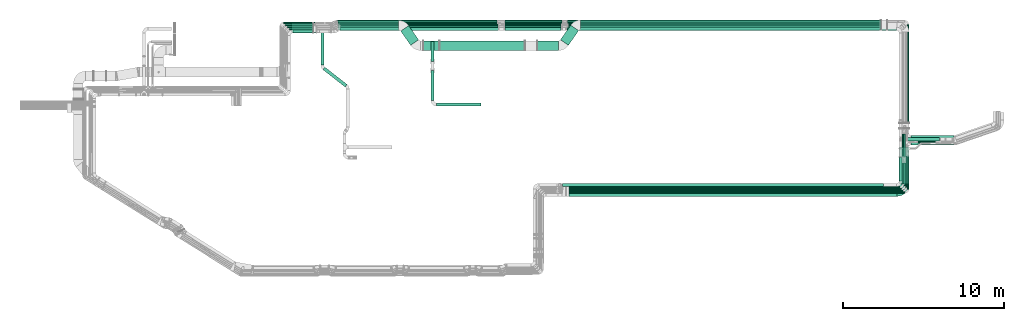
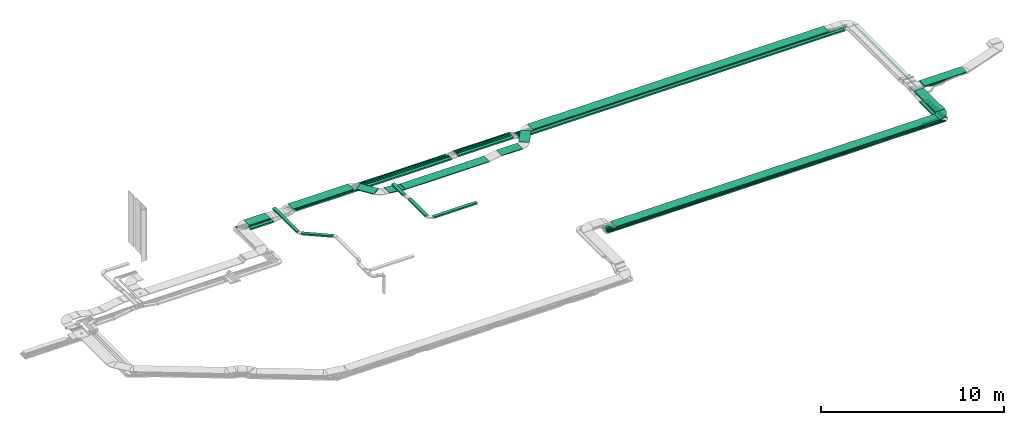
# One storey, part 6 of 38: 55 flow segments, 1 flow fitting.
"""IFC2X3 building model written with IfcOpenShell, lengths in millimetres."""

from ifc_helpers import new_model, entity, si_unit, converted_unit, derived_unit, direction, frame, frame_2d, origin, origin_2d_with_axis, place, context, subcontext, project, spatial, polyline, circle_curve, parameter, trimmed, segment, composite_curve, rectangle, outline, extrude, source, transform, mapped, material, type_object, type_shapes, element, save


model = new_model("IFC2X3")

# Units and contexts
model_context = context("Model", 3, precision=0.01, world=origin(), true_north=direction((6.12303176911189e-17, 1.0)))
body_context = subcontext(model_context, "Body", "Model", "MODEL_VIEW")
ifc_project = project(units=[si_unit("LENGTHUNIT", "METRE", prefix="MILLI"), si_unit("AREAUNIT", "SQUARE_METRE"), si_unit("VOLUMEUNIT", "CUBIC_METRE"), converted_unit("PLANEANGLEUNIT", "DEGREE", entity("IfcRatioMeasure", 0.0174532925199433), si_unit("PLANEANGLEUNIT", "RADIAN"), dimensions=[0, 0, 0, 0, 0, 0, 0]), si_unit("MASSUNIT", "GRAM", prefix="KILO"), derived_unit("MASSDENSITYUNIT", [(si_unit("MASSUNIT", "GRAM", prefix="KILO"), 1), (si_unit("LENGTHUNIT", "METRE"), -3)]), derived_unit("MOMENTOFINERTIAUNIT", [(si_unit("LENGTHUNIT", "METRE"), 4)]), si_unit("TIMEUNIT", "SECOND"), si_unit("FREQUENCYUNIT", "HERTZ"), si_unit("THERMODYNAMICTEMPERATUREUNIT", "DEGREE_CELSIUS"), derived_unit("THERMALTRANSMITTANCEUNIT", [(si_unit("MASSUNIT", "GRAM", prefix="KILO"), 1), (si_unit("THERMODYNAMICTEMPERATUREUNIT", "KELVIN"), -1), (si_unit("TIMEUNIT", "SECOND"), -3)]), derived_unit("VOLUMETRICFLOWRATEUNIT", [(si_unit("LENGTHUNIT", "METRE"), 3), (si_unit("TIMEUNIT", "SECOND"), -1)]), derived_unit("MASSFLOWRATEUNIT", [(si_unit("MASSUNIT", "GRAM", prefix="KILO"), 1), (si_unit("TIMEUNIT", "SECOND"), -1)]), derived_unit("ROTATIONALFREQUENCYUNIT", [(si_unit("TIMEUNIT", "SECOND"), -1)]), si_unit("ELECTRICCURRENTUNIT", "AMPERE"), si_unit("ELECTRICVOLTAGEUNIT", "VOLT"), si_unit("POWERUNIT", "WATT"), si_unit("FORCEUNIT", "NEWTON", prefix="KILO"), si_unit("ILLUMINANCEUNIT", "LUX"), si_unit("LUMINOUSFLUXUNIT", "LUMEN"), si_unit("LUMINOUSINTENSITYUNIT", "CANDELA"), derived_unit("USERDEFINED", [(si_unit("MASSUNIT", "GRAM", prefix="KILO"), -1), (si_unit("LENGTHUNIT", "METRE"), -2), (si_unit("TIMEUNIT", "SECOND"), 3), (si_unit("LUMINOUSFLUXUNIT", "LUMEN"), 1)]), derived_unit("LINEARVELOCITYUNIT", [(si_unit("LENGTHUNIT", "METRE"), 1), (si_unit("TIMEUNIT", "SECOND"), -1)]), si_unit("PRESSUREUNIT", "PASCAL"), derived_unit("USERDEFINED", [(si_unit("LENGTHUNIT", "METRE"), -2), (si_unit("MASSUNIT", "GRAM", prefix="KILO"), 1), (si_unit("TIMEUNIT", "SECOND"), -2)]), derived_unit("LINEARFORCEUNIT", [(si_unit("MASSUNIT", "GRAM", prefix="KILO"), 1), (si_unit("LENGTHUNIT", "METRE"), 1), (si_unit("TIMEUNIT", "SECOND"), -2), (si_unit("LENGTHUNIT", "METRE"), -1)]), derived_unit("PLANARFORCEUNIT", [(si_unit("MASSUNIT", "GRAM", prefix="KILO"), 1), (si_unit("LENGTHUNIT", "METRE"), 1), (si_unit("TIMEUNIT", "SECOND"), -2), (si_unit("LENGTHUNIT", "METRE"), -2)])], contexts=[model_context])

# Site, building, storey
site_placement = place(None, frame((0.0, -0.00077364408347762, 0.0)))
site = spatial("IfcSite", under=ifc_project, at=site_placement, CompositionType="ELEMENT")
building_placement = place(site_placement, origin())
building = spatial("IfcBuilding", under=site, at=building_placement, CompositionType="ELEMENT")
storey_placement = place(building_placement, frame((0.0, 0.0, 4200.0)))
storey = spatial("IfcBuildingStorey", under=building, at=storey_placement, CompositionType="ELEMENT", Elevation=4200.0)

# Flow segments
cable_carrier_segment_type = type_object("IfcCableCarrierSegmentType", PredefinedType="CABLETRAYSEGMENT")
flow_segment_1_placement = place(storey_placement, frame((60531.4530273013, 5610.19378076405, 2500.0)))
element("IfcFlowSegment", 1, at=flow_segment_1_placement, inside=storey, type_object=cable_carrier_segment_type, context=body_context, shape_type="SweptSolid", body=[
    extrude(rectangle(XDim=1096.23000000496, YDim=99.9999999999989, at=origin_2d_with_axis()), frame((548.115000002479, 50.0, 0.0)), (0.0, 0.0, 1.0), 99.9999999999989),
])
flow_segment_2_placement = place(storey_placement, frame((40879.6888731716, 15938.4164270114, 2546.7)))
element("IfcFlowSegment", 2, at=flow_segment_2_placement, inside=storey, type_object=cable_carrier_segment_type, context=body_context, shape_type="SweptSolid", body=[
    extrude(rectangle(XDim=20847.646391026, YDim=99.9999999999989, at=frame_2d((4.54747350886464e-12, 0.0), x_axis=(1.0, 0.0))), frame((10423.823195513, 50.0, 0.0)), (0.0, 0.0, 1.0), 49.9999999999995),
])
flow_segment_3_placement = place(storey_placement, frame((32941.5946570979, 14271.8475478723, 2674.65890094892)))
element("IfcFlowSegment", 3, at=flow_segment_3_placement, inside=storey, type_object=cable_carrier_segment_type, context=body_context, shape_type="SweptSolid", body=[
    extrude(rectangle(XDim=5286.86759215359, YDim=600.000000000002, at=origin_2d_with_axis()), frame((2643.43379607679, 300.0, 0.0)), (0.0, 0.0, 1.0), 49.9999999999995),
])
flow_segment_4_placement = place(storey_placement, frame((30526.4258533694, 14592.4843726533, 2793.21248393464)))
element("IfcFlowSegment", 4, at=flow_segment_4_placement, inside=storey, type_object=cable_carrier_segment_type, context=body_context, shape_type="SweptSolid", body=[
    extrude(rectangle(XDim=1076.8183356809, YDim=600.000000000004, at=frame_2d((-3.97903932025656e-13, -2.38742359215394e-12), x_axis=(1.0, 0.0))), frame((554.564425075352, 613.111901405759, 0.0), z_axis=(0.0, 0.0, 1.0), x_axis=(0.573576436351025, -0.819152044289006, 0.0)), (0.0, 0.0, 1.0), 49.9999999999994),
])
flow_segment_5_placement = place(storey_placement, frame((31926.7772360649, 14271.8475478723, 2675.78426037612)))
element("IfcFlowSegment", 5, at=flow_segment_5_placement, inside=storey, type_object=cable_carrier_segment_type, context=body_context, shape_type="SweptSolid", body=[
    extrude(rectangle(XDim=50.000000000001, YDim=600.000000000002, at=frame_2d((0.0, 1.07469588783715e-12), x_axis=(0.0, 1.0))), frame((2.90922213003945, 300.0, 141.472712569179), z_axis=(0.993206062484992, 0.0, -0.116368885201576), x_axis=(0.0, 1.0, 0.0)), (0.0, 0.0, 1.0), 1002.35179537027),
])
flow_segment_6_placement = place(storey_placement, frame((40446.4961619178, 14592.4843726533, 2798.17400237658)))
element("IfcFlowSegment", 6, at=flow_segment_6_placement, inside=storey, type_object=cable_carrier_segment_type, context=body_context, shape_type="SweptSolid", body=[
    extrude(rectangle(XDim=1109.5441562498, YDim=599.999999999997, at=origin_2d_with_axis()), frame((563.949804844644, 626.515612815777, 0.0), z_axis=(0.0, 0.0, 1.0), x_axis=(-0.573576436351054, -0.819152044288987, 0.0)), (0.0, 0.0, 1.0), 49.9999999999995),
])
flow_segment_7_placement = place(storey_placement, frame((39015.982591569, 14271.8475478723, 2798.17400237658)))
element("IfcFlowSegment", 7, at=flow_segment_7_placement, inside=storey, type_object=cable_carrier_segment_type, context=body_context, shape_type="SweptSolid", body=[
    extrude(rectangle(XDim=1306.06718726911, YDim=600.000000000002, at=frame_2d((-4.32009983342141e-12, 0.0), x_axis=(1.0, 0.0))), frame((653.033593634561, 300.0, 0.0)), (0.0, 0.0, 1.0), 49.9999999999995),
])
flow_segment_8_placement = place(storey_placement, frame((26622.1253290445, 15539.3450002459, 2793.21248393464)))
element("IfcFlowSegment", 8, at=flow_segment_8_placement, inside=storey, type_object=cable_carrier_segment_type, context=body_context, shape_type="SweptSolid", body=[
    extrude(rectangle(XDim=3779.85414124522, YDim=599.999999999998, at=frame_2d((-4.43378667114303e-12, 2.1600499167107e-12), x_axis=(1.0, 0.0))), frame((1889.92707062261, 300.0, 0.0), z_axis=(0.0, 0.0, 1.0), x_axis=(-1.0, 0.0, 0.0)), (0.0, 0.0, 1.0), 49.9999999999995),
])
flow_segment_9_placement = place(storey_placement, frame((26552.1706226276, 16039.1762792239, 2639.20628594077)))
element("IfcFlowSegment", 9, at=flow_segment_9_placement, inside=storey, type_object=cable_carrier_segment_type, context=body_context, shape_type="SweptSolid", body=[
    extrude(rectangle(XDim=9961.15558282247, YDim=99.9999999999989, at=frame_2d((-2.27373675443232e-12, -1.08357767203415e-12), x_axis=(1.0, 0.0))), frame((4980.57779141124, 50.0, 0.0), z_axis=(0.0, 0.0, 1.0), x_axis=(-1.0, 0.0, 0.0)), (0.0, 0.0, 1.0), 49.9999999999995),
])
flow_segment_10_placement = place(storey_placement, frame((26760.6550635704, 15519.4933785571, 2639.20628594082)))
element("IfcFlowSegment", 10, at=flow_segment_10_placement, inside=storey, type_object=cable_carrier_segment_type, context=body_context, shape_type="SweptSolid", body=[
    extrude(rectangle(XDim=9824.01158628356, YDim=199.999999999998, at=frame_2d((1.81898940354586e-12, 0.0), x_axis=(1.0, 0.0))), frame((4912.00579314178, 100.0, 0.0)), (0.0, 0.0, 1.0), 99.9999999999989),
])
flow_segment_11_placement = place(storey_placement, frame((23749.9930091024, 15379.3450002459, 2823.51525104152)))
element("IfcFlowSegment", 11, at=flow_segment_11_placement, inside=storey, type_object=cable_carrier_segment_type, context=body_context, shape_type="SweptSolid", body=[
    extrude(rectangle(XDim=1336.47856825049, YDim=599.999999999998, at=origin_2d_with_axis()), frame((668.239284125245, 300.0, 0.0), z_axis=(0.0, 0.0, 1.0), x_axis=(-1.0, 0.0, 0.0)), (0.0, 0.0, 1.0), 49.9999999999995),
])
flow_segment_12_placement = place(storey_placement, frame((23604.0702916724, 15574.4779321218, 2520.16463947554)))
element("IfcFlowSegment", 12, at=flow_segment_12_placement, inside=storey, type_object=cable_carrier_segment_type, context=body_context, shape_type="SweptSolid", body=[
    extrude(rectangle(XDim=1663.41414412451, YDim=99.9999999999989, at=origin_2d_with_axis()), frame((831.707072062254, 50.0, 0.0)), (0.0, 0.0, 1.0), 99.9999999999989),
])
flow_segment_13_placement = place(storey_placement, frame((23479.8695134699, 15694.4779321217, 2524.49099867056)))
element("IfcFlowSegment", 13, at=flow_segment_13_placement, inside=storey, type_object=cable_carrier_segment_type, context=body_context, shape_type="SweptSolid", body=[
    extrude(rectangle(XDim=1787.61492232689, YDim=99.9999999999989, at=origin_2d_with_axis()), frame((893.807461163445, 50.0, 0.0)), (0.0, 0.0, 1.0), 100.000000000001),
])
flow_segment_14_placement = place(storey_placement, frame((23364.0702916722, 15820.6629696994, 2524.49099867056)))
element("IfcFlowSegment", 14, at=flow_segment_14_placement, inside=storey, type_object=cable_carrier_segment_type, context=body_context, shape_type="SweptSolid", body=[
    extrude(rectangle(XDim=1830.52522556067, YDim=99.9999999999989, at=frame_2d((-2.1600499167107e-12, 1.08357767203415e-12), x_axis=(1.0, 0.0))), frame((915.262612780335, 50.0, 0.0)), (0.0, 0.0, 1.0), 49.9999999999995),
])
flow_segment_15_placement = place(storey_placement, frame((23829.9930091024, 15355.6629696993, 2524.49099867058)))
element("IfcFlowSegment", 15, at=flow_segment_15_placement, inside=storey, type_object=cable_carrier_segment_type, context=body_context, shape_type="SweptSolid", body=[
    extrude(rectangle(XDim=1437.49142669443, YDim=200.000000000002, at=origin_2d_with_axis()), frame((718.745713347214, 100.0, 0.0)), (0.0, 0.0, 1.0), 100.000000000001),
])
flow_segment_16_placement = place(storey_placement, frame((26772.8992160055, 15728.4164270115, 2634.94591164699)))
element("IfcFlowSegment", 16, at=flow_segment_16_placement, inside=storey, type_object=cable_carrier_segment_type, context=body_context, shape_type="SweptSolid", body=[
    extrude(rectangle(XDim=9811.7674338486, YDim=99.9999999999989, at=frame_2d((2.27373675443232e-12, 0.0), x_axis=(1.0, 0.0))), frame((4905.8837169243, 50.0, 0.0)), (0.0, 0.0, 1.0), 99.9999999999989),
])
flow_segment_17_placement = place(storey_placement, frame((26698.0133518923, 15833.4164270114, 2639.2062859403)))
element("IfcFlowSegment", 17, at=flow_segment_17_placement, inside=storey, type_object=cable_carrier_segment_type, context=body_context, shape_type="SweptSolid", body=[
    extrude(rectangle(XDim=9886.65329795796, YDim=99.9999999999989, at=frame_2d((2.27373675443232e-12, -2.16715534406831e-12), x_axis=(1.0, 0.0))), frame((4943.32664897898, 50.0, 0.0)), (0.0, 0.0, 1.0), 100.000000000001),
])
flow_segment_18_placement = place(storey_placement, frame((26622.1706226276, 15938.4164270114, 2639.20628594077)))
element("IfcFlowSegment", 18, at=flow_segment_18_placement, inside=storey, type_object=cable_carrier_segment_type, context=body_context, shape_type="SweptSolid", body=[
    extrude(rectangle(XDim=9891.15558282195, YDim=99.9999999999989, at=origin_2d_with_axis()), frame((4945.57779141097, 50.0, 0.0), z_axis=(0.0, 0.0, 1.0), x_axis=(-1.0, 0.0, 0.0)), (0.0, 0.0, 1.0), 49.9999999999995),
])
flow_segment_19_placement = place(storey_placement, frame((60516.4529536295, 5505.19378076411, 2500.0)))
element("IfcFlowSegment", 19, at=flow_segment_19_placement, inside=storey, type_object=cable_carrier_segment_type, context=body_context, shape_type="SweptSolid", body=[
    extrude(rectangle(XDim=1209.97480888635, YDim=99.999999999999, at=frame_2d((4.37694325228222e-12, 5.40012479177676e-13), x_axis=(1.0, 0.0))), frame((604.987478054437, 50.0008906856488, 1.44444187810677e-06)), (0.0, 0.0, 1.0), 49.9999999999995),
])
flow_segment_20_placement = place(storey_placement, frame((60526.4530273013, 5715.19378076404, 2500.0)))
element("IfcFlowSegment", 20, at=flow_segment_20_placement, inside=storey, type_object=cable_carrier_segment_type, context=body_context, shape_type="SweptSolid", body=[
    extrude(rectangle(XDim=998.830474924462, YDim=99.9999999999989, at=origin_2d_with_axis()), frame((499.415237462231, 50.0, 0.0)), (0.0, 0.0, 1.0), 100.000000000001),
])
flow_segment_21_placement = place(storey_placement, frame((61676.2835022257, 5966.19378076404, 2500.0)))
element("IfcFlowSegment", 21, at=flow_segment_21_placement, inside=storey, type_object=cable_carrier_segment_type, context=body_context, shape_type="SweptSolid", body=[
    extrude(rectangle(XDim=1336.14812837233, YDim=99.9999999999946, at=frame_2d((5.6843418860808e-13, 0.0), x_axis=(1.0, 0.0))), frame((50.0, 668.074064186164, 0.0), z_axis=(0.0, 0.0, 1.0), x_axis=(0.0, 1.0, 0.0)), (0.0, 0.0, 1.0), 100.000000000001),
])
flow_segment_22_placement = place(storey_placement, frame((40965.9770802575, 5216.65700227204, 2859.5)))
element("IfcFlowSegment", 22, at=flow_segment_22_placement, inside=storey, type_object=cable_carrier_segment_type, context=body_context, shape_type="SweptSolid", body=[
    extrude(rectangle(XDim=20377.0563312766, YDim=600.0, at=origin_2d_with_axis()), frame((10188.5281656383, 300.0, 0.0), z_axis=(0.0, 0.0, 1.0), x_axis=(-1.0, 0.0, 0.0)), (0.0, 0.0, 1.0), 49.9999999999995),
])
flow_segment_23_placement = place(storey_placement, frame((61982.1830273061, 5651.19378076404, 2500.0)))
element("IfcFlowSegment", 23, at=flow_segment_23_placement, inside=storey, type_object=cable_carrier_segment_type, context=body_context, shape_type="SweptSolid", body=[
    extrude(rectangle(XDim=2060.92376704407, YDim=99.9999999999946, at=origin_2d_with_axis()), frame((50.0, 1030.46188352204, 0.0), z_axis=(0.0, 0.0, 1.0), x_axis=(0.0, -1.0, 0.0)), (0.0, 0.0, 1.0), 49.9999999999995),
])
flow_segment_24_placement = place(storey_placement, frame((61494.0334115341, 5967.65700227204, 2859.5)))
element("IfcFlowSegment", 24, at=flow_segment_24_placement, inside=storey, type_object=cable_carrier_segment_type, context=body_context, shape_type="SweptSolid", body=[
    extrude(rectangle(XDim=2295.66681678748, YDim=600.000000000002, at=origin_2d_with_axis()), frame((300.0, 1147.83340839374, 0.0), z_axis=(0.0, 0.0, 1.0), x_axis=(0.0, 1.0, 0.0)), (0.0, 0.0, 1.0), 49.9999999999995),
])
flow_segment_25_placement = place(storey_placement, frame((62224.0332125533, 8393.32381906899, 2859.50000000158)))
element("IfcFlowSegment", 25, at=flow_segment_25_placement, inside=storey, type_object=cable_carrier_segment_type, context=body_context, shape_type="SweptSolid", body=[
    extrude(rectangle(XDim=2650.5603253686, YDim=599.999999980996, at=frame_2d((4.43378667114303e-12, 0.0), x_axis=(1.0, 0.0))), frame((1325.28056060398, 300.0, 0.0105482137829767), z_axis=(-7.95923313382307e-06, 0.0, 1.0), x_axis=(-1.0, 0.0, -7.95923313382307e-06)), (0.0, 0.0, 1.0), 49.9999999984147),
])
flow_segment_26_placement = place(storey_placement, frame((40879.6753929281, 16039.1762792239, 2546.70628594078)))
element("IfcFlowSegment", 26, at=flow_segment_26_placement, inside=storey, type_object=cable_carrier_segment_type, context=body_context, shape_type="SweptSolid", body=[
    extrude(rectangle(XDim=19890.0764714327, YDim=99.9999999999989, at=frame_2d((0.0, -1.08357767203415e-12), x_axis=(1.0, 0.0))), frame((9945.03823571637, 50.0, 0.0), z_axis=(0.0, 0.0, 1.0), x_axis=(-1.0, 0.0, 0.0)), (0.0, 0.0, 1.0), 49.9999999999995),
])
flow_segment_27_placement = place(storey_placement, frame((61982.1830273061, 8367.18210775868, 2577.30800926447)))
element("IfcFlowSegment", 27, at=flow_segment_27_placement, inside=storey, type_object=cable_carrier_segment_type, context=body_context, shape_type="SweptSolid", body=[
    extrude(rectangle(XDim=7520.99417146538, YDim=99.9999999999946, at=frame_2d((-6.82121026329696e-13, 0.0), x_axis=(1.0, 0.0))), frame((50.0, 3760.49708573269, 0.0), z_axis=(0.0, 0.0, 1.0), x_axis=(0.0, -1.0, 0.0)), (0.0, 0.0, 1.0), 49.9999999999995),
])
flow_segment_28_placement = place(storey_placement, frame((41698.8421546868, 15566.1524230659, 2798.17400237658)))
element("IfcFlowSegment", 28, at=flow_segment_28_placement, inside=storey, type_object=cable_carrier_segment_type, context=body_context, shape_type="SweptSolid", body=[
    extrude(rectangle(XDim=18645.0038607137, YDim=600.000000000002, at=origin_2d_with_axis()), frame((9322.50193035687, 300.0, 0.0)), (0.0, 0.0, 1.0), 49.9999999999995),
])
flow_segment_29_placement = place(storey_placement, frame((40581.1830273063, 5820.36768039066, 2500.0)))
element("IfcFlowSegment", 29, at=flow_segment_29_placement, inside=storey, type_object=cable_carrier_segment_type, context=body_context, shape_type="SweptSolid", body=[
    extrude(rectangle(XDim=19937.7300000051, YDim=200.0, at=frame_2d((3.63797880709171e-12, 0.0), x_axis=(1.0, 0.0))), frame((9968.86500000255, 100.0, 0.0)), (0.0, 0.0, 1.0), 99.9999999999989),
])
flow_segment_30_placement = place(storey_placement, frame((40581.1830273063, 5715.19378076404, 2500.0)))
element("IfcFlowSegment", 30, at=flow_segment_30_placement, inside=storey, type_object=cable_carrier_segment_type, context=body_context, shape_type="SweptSolid", body=[
    extrude(rectangle(XDim=19942.7300000051, YDim=99.9999999999989, at=origin_2d_with_axis()), frame((9971.36500000257, 50.0, 0.0)), (0.0, 0.0, 1.0), 100.000000000001),
])
flow_segment_31_placement = place(storey_placement, frame((40581.1830273063, 5610.19378076405, 2500.0)))
element("IfcFlowSegment", 31, at=flow_segment_31_placement, inside=storey, type_object=cable_carrier_segment_type, context=body_context, shape_type="SweptSolid", body=[
    extrude(rectangle(XDim=19947.7300000051, YDim=100.000000000001, at=frame_2d((-4.54747350886464e-12, -5.43565192856477e-13), x_axis=(1.0, 0.0))), frame((9973.86500000257, 50.0, 0.0)), (0.0, 0.0, 1.0), 99.9999999999989),
])
flow_segment_32_placement = place(storey_placement, frame((40556.1830273063, 5505.19378076405, 2500.0)))
element("IfcFlowSegment", 32, at=flow_segment_32_placement, inside=storey, type_object=cable_carrier_segment_type, context=body_context, shape_type="SweptSolid", body=[
    extrude(rectangle(XDim=19957.730000005, YDim=99.9999999999989, at=frame_2d((4.54747350886464e-12, -5.40012479177676e-13), x_axis=(1.0, 0.0))), frame((9978.86500000248, 50.0, 0.0)), (0.0, 0.0, 1.0), 49.9999999999995),
])
flow_segment_33_placement = place(storey_placement, frame((40556.1830273063, 5400.19378076406, 2500.0)))
element("IfcFlowSegment", 33, at=flow_segment_33_placement, inside=storey, type_object=cable_carrier_segment_type, context=body_context, shape_type="SweptSolid", body=[
    extrude(rectangle(XDim=19930.0, YDim=100.000000000001, at=frame_2d((4.54747350886464e-12, 5.43565192856477e-13), x_axis=(1.0, 0.0))), frame((9965.0, 50.0, 0.0)), (0.0, 0.0, 1.0), 49.9999999999995),
])
flow_segment_34_placement = place(storey_placement, frame((61471.1830273063, 6171.36768039067, 2500.0)))
element("IfcFlowSegment", 34, at=flow_segment_34_placement, inside=storey, type_object=cable_carrier_segment_type, context=body_context, shape_type="SweptSolid", body=[
    extrude(rectangle(XDim=1456.20731160175, YDim=200.000000000007, at=frame_2d((5.11590769747272e-13, 0.0), x_axis=(1.0, 0.0))), frame((100.0, 728.103655800873, 0.0), z_axis=(0.0, 0.0, 1.0), x_axis=(0.0, 1.0, 0.0)), (0.0, 0.0, 1.0), 99.9999999999989),
])
flow_segment_35_placement = place(storey_placement, frame((62631.0084609008, 8547.44797903922, 2629.8692484984)))
element("IfcFlowSegment", 35, at=flow_segment_35_placement, inside=storey, type_object=cable_carrier_segment_type, context=body_context, shape_type="SweptSolid", body=[
    extrude(rectangle(XDim=1135.7210445927, YDim=100.000000000001, at=origin_2d_with_axis()), frame((567.860522296351, 50.0, 0.0), z_axis=(0.0, 0.0, 1.0), x_axis=(-1.0, 0.0, 0.0)), (0.0, 0.0, 1.0), 49.9999999999995),
])
flow_segment_36_placement = place(storey_placement, frame((36993.6089001651, 15519.4933785571, 2686.70628594082)))
element("IfcFlowSegment", 36, at=flow_segment_36_placement, inside=storey, type_object=cable_carrier_segment_type, context=body_context, shape_type="SweptSolid", body=[
    extrude(rectangle(XDim=3486.75170485592, YDim=199.999999999998, at=origin_2d_with_axis()), frame((1743.37585242796, 100.0, 0.0), z_axis=(0.0, 0.0, 1.0), x_axis=(-1.0, 0.0, 0.0)), (0.0, 0.0, 1.0), 99.9999999999989),
])
flow_segment_37_placement = place(storey_placement, frame((36994.1252547275, 15728.4164270115, 2682.50944080412)))
element("IfcFlowSegment", 37, at=flow_segment_37_placement, inside=storey, type_object=cable_carrier_segment_type, context=body_context, shape_type="SweptSolid", body=[
    extrude(rectangle(XDim=3495.23551373344, YDim=99.9999999999989, at=frame_2d((0.0, -2.16715534406831e-12), x_axis=(1.0, 0.0))), frame((1747.61775686672, 50.0, 0.0), z_axis=(0.0, 0.0, 1.0), x_axis=(-1.0, 0.0, 0.0)), (0.0, 0.0, 1.0), 100.000000000001),
])
flow_segment_38_placement = place(storey_placement, frame((36993.6089001652, 15833.4164270114, 2686.70628594076)))
element("IfcFlowSegment", 38, at=flow_segment_38_placement, inside=storey, type_object=cable_carrier_segment_type, context=body_context, shape_type="SweptSolid", body=[
    extrude(rectangle(XDim=3486.75170485595, YDim=99.9999999999989, at=frame_2d((-2.1600499167107e-12, 1.08357767203415e-12), x_axis=(1.0, 0.0))), frame((1743.37585242798, 50.0, 0.0), z_axis=(0.0, 0.0, 1.0), x_axis=(-1.0, 0.0, 0.0)), (0.0, 0.0, 1.0), 100.0),
])
flow_segment_39_placement = place(storey_placement, frame((36998.3200709673, 15938.4164270114, 2686.70628594076)))
element("IfcFlowSegment", 39, at=flow_segment_39_placement, inside=storey, type_object=cable_carrier_segment_type, context=body_context, shape_type="SweptSolid", body=[
    extrude(rectangle(XDim=3546.73794019873, YDim=99.9999999999989, at=frame_2d((2.1600499167107e-12, 0.0), x_axis=(1.0, 0.0))), frame((1773.36897009936, 50.0, 0.0), z_axis=(0.0, 0.0, 1.0), x_axis=(-1.0, 0.0, 0.0)), (0.0, 0.0, 1.0), 49.9999999999995),
])
flow_segment_40_placement = place(storey_placement, frame((36998.3200709674, 16039.1762792239, 2686.70628594076)))
element("IfcFlowSegment", 40, at=flow_segment_40_placement, inside=storey, type_object=cable_carrier_segment_type, context=body_context, shape_type="SweptSolid", body=[
    extrude(rectangle(XDim=3546.73794019871, YDim=99.9999999999989, at=frame_2d((2.1600499167107e-12, 1.08357767203415e-12), x_axis=(1.0, 0.0))), frame((1773.36897009935, 50.0, 0.0), z_axis=(0.0, 0.0, 1.0), x_axis=(-1.0, 0.0, 0.0)), (0.0, 0.0, 1.0), 49.9999999999995),
])
flow_segment_41_placement = place(storey_placement, frame((60512.453027301, 5400.19378076404, 2500.0)))
element("IfcFlowSegment", 41, at=flow_segment_41_placement, inside=storey, type_object=cable_carrier_segment_type, context=body_context, shape_type="SweptSolid", body=[
    extrude(rectangle(XDim=1318.73000000509, YDim=99.9999999999989, at=origin_2d_with_axis()), frame((659.365000002545, 50.0, 0.0)), (0.0, 0.0, 1.0), 49.9999999999995),
])
flow_segment_42_placement = place(storey_placement, frame((61778.6830273062, 5861.19378076405, 2500.0)))
element("IfcFlowSegment", 42, at=flow_segment_42_placement, inside=storey, type_object=cable_carrier_segment_type, context=body_context, shape_type="SweptSolid", body=[
    extrude(rectangle(XDim=1441.15238333803, YDim=99.9999999999946, at=frame_2d((-5.6843418860808e-13, -8.66506866259442e-12), x_axis=(1.0, 0.0))), frame((50.0, 720.576191669015, 0.0), z_axis=(0.0, 0.0, 1.0), x_axis=(0.0, 1.0, 0.0)), (0.0, 0.0, 1.0), 99.9999999999989),
])
flow_segment_43_placement = place(storey_placement, frame((61877.4282836682, 5756.08200771213, 2500.0)))
element("IfcFlowSegment", 43, at=flow_segment_43_placement, inside=storey, type_object=cable_carrier_segment_type, context=body_context, shape_type="SweptSolid", body=[
    extrude(rectangle(XDim=1973.91369428736, YDim=100.0, at=frame_2d((1.08002495835535e-12, 0.0), x_axis=(1.0, 0.0))), frame((50.4482935103162, 986.979456488379, 0.0), z_axis=(0.0, 0.0, 1.0), x_axis=(-0.000454223170527662, -0.99999989684065, 0.0)), (0.0, 0.0, 1.0), 50.0000000000005),
])
flow_segment_44_placement = place(storey_placement, frame((61778.6830273062, 7659.92104473248, 2530.73189581327)))
element("IfcFlowSegment", 44, at=flow_segment_44_placement, inside=storey, type_object=cable_carrier_segment_type, context=body_context, shape_type="SweptSolid", body=[
    extrude(rectangle(XDim=1431.01738845492, YDim=99.9999999999946, at=frame_2d((-5.11590769747272e-13, 0.0), x_axis=(1.0, 0.0))), frame((50.0, 715.508694227461, 0.0), z_axis=(0.0, 0.0, 1.0), x_axis=(0.0, -1.0, 0.0)), (0.0, 0.0, 1.0), 100.000000000001),
])
flow_segment_45_placement = place(storey_placement, frame((61676.2835022257, 7659.92526482122, 2530.73266627695)))
element("IfcFlowSegment", 45, at=flow_segment_45_placement, inside=storey, type_object=cable_carrier_segment_type, context=body_context, shape_type="SweptSolid", body=[
    extrude(rectangle(XDim=1431.01812835987, YDim=99.9999999999946, at=origin_2d_with_axis()), frame((50.0, 715.509064179935, 0.0), z_axis=(0.0, 0.0, 1.0), x_axis=(0.0, -1.0, 0.0)), (0.0, 0.0, 1.0), 100.000000000001),
])
flow_segment_46_placement = place(storey_placement, frame((61916.3104649988, 8663.78573364408, 2582.6)))
element("IfcFlowSegment", 46, at=flow_segment_46_placement, inside=storey, type_object=cable_carrier_segment_type, context=body_context, shape_type="SweptSolid", body=[
    extrude(rectangle(XDim=2086.73632078342, YDim=200.0, at=frame_2d((4.32009983342141e-12, 5.47117906535277e-13), x_axis=(1.0, 0.0))), frame((1043.3681603917, 100.0, 0.0), z_axis=(0.0, 0.0, 1.0), x_axis=(-1.0, 0.0, 0.0)), (0.0, 0.0, 1.0), 100.000000000001),
])
flow_segment_47_placement = place(storey_placement, frame((40837.0058010514, 15519.4933785574, 2546.77233935132)))
element("IfcFlowSegment", 47, at=flow_segment_47_placement, inside=storey, type_object=cable_carrier_segment_type, context=body_context, shape_type="SweptSolid", body=[
    extrude(rectangle(XDim=20483.1778787901, YDim=199.999999999998, at=frame_2d((4.54747350886464e-12, 0.0), x_axis=(1.0, 0.0))), frame((10241.588939395, 100.0, 0.0)), (0.0, 0.0, 1.0), 99.9999999999989),
])
flow_segment_48_placement = place(storey_placement, frame((40929.0021095008, 15728.4164270114, 2503.8737561994)))
element("IfcFlowSegment", 48, at=flow_segment_48_placement, inside=storey, type_object=cable_carrier_segment_type, context=body_context, shape_type="SweptSolid", body=[
    extrude(rectangle(XDim=20596.2819049685, YDim=99.9999999999989, at=origin_2d_with_axis()), frame((10298.1409524843, 50.0, 0.0)), (0.0, 0.0, 1.0), 99.9999999999989),
])
flow_segment_49_placement = place(storey_placement, frame((40929.9370680811, 15833.4164270114, 2503.43777785335)))
element("IfcFlowSegment", 49, at=flow_segment_49_placement, inside=storey, type_object=cable_carrier_segment_type, context=body_context, shape_type="SweptSolid", body=[
    extrude(rectangle(XDim=20697.7459592251, YDim=99.9999999999989, at=frame_2d((-4.54747350886464e-12, 0.0), x_axis=(1.0, 0.0))), frame((10348.8729796126, 50.0, 0.0)), (0.0, 0.0, 1.0), 100.000000000001),
])
flow_segment_50_placement = place(storey_placement, frame((23259.86951347, 15929.5860181536, 2524.49099867056)))
element("IfcFlowSegment", 50, at=flow_segment_50_placement, inside=storey, type_object=cable_carrier_segment_type, context=body_context, shape_type="SweptSolid", body=[
    extrude(rectangle(XDim=1953.64153674384, YDim=99.9999999999989, at=frame_2d((0.0, 1.08357767203415e-12), x_axis=(1.0, 0.0))), frame((976.82076837192, 50.0, 0.0)), (0.0, 0.0, 1.0), 49.9999999999995),
])
flow_segment_51_placement = place(storey_placement, frame((25693.3432506155, 12000.9140450172, 2930.0)))
element("IfcFlowSegment", 51, at=flow_segment_51_placement, inside=storey, type_object=cable_carrier_segment_type, context=body_context, shape_type="SweptSolid", body=[
    extrude(rectangle(XDim=1754.13370571707, YDim=200.000000000001, at=origin_2d_with_axis()), frame((752.704259217104, 618.777347950782, 0.0), z_axis=(0.0, 0.0, 1.0), x_axis=(-0.788010753606729, 0.615661475325649, 0.0)), (0.0, 0.0, 1.0), 99.9999999999989),
])
flow_segment_52_placement = place(storey_placement, frame((25558.0367562259, 13358.2860154351, 2930.0)))
element("IfcFlowSegment", 52, at=flow_segment_52_placement, inside=storey, type_object=cable_carrier_segment_type, context=body_context, shape_type="SweptSolid", body=[
    extrude(rectangle(XDim=2621.30000271867, YDim=199.999999999998, at=frame_2d((1.02318153949454e-12, 0.0), x_axis=(1.0, 0.0))), frame((100.0, 1310.65000135933, 0.0), z_axis=(0.0, 0.0, 1.0), x_axis=(0.0, 1.0, 0.0)), (0.0, 0.0, 1.0), 99.9999999999989),
])
flow_segment_53_placement = place(storey_placement, frame((32398.8792683526, 11166.8101355476, 2930.0)))
element("IfcFlowSegment", 53, at=flow_segment_53_placement, inside=storey, type_object=cable_carrier_segment_type, context=body_context, shape_type="SweptSolid", body=[
    extrude(rectangle(XDim=1863.7516446428, YDim=199.999999999998, at=frame_2d((-1.08002495835535e-12, -2.16715534406831e-12), x_axis=(1.0, 0.0))), frame((100.0, 931.8758223214, 0.0), z_axis=(0.0, 0.0, 1.0), x_axis=(0.0, 1.0, 0.0)), (0.0, 0.0, 1.0), 99.9999999999989),
])
flow_segment_54_placement = place(storey_placement, frame((32749.8792683526, 10815.8101355476, 2930.0)))
element("IfcFlowSegment", 54, at=flow_segment_54_placement, inside=storey, type_object=cable_carrier_segment_type, context=body_context, shape_type="SweptSolid", body=[
    extrude(rectangle(XDim=2749.00000000001, YDim=199.999999999998, at=frame_2d((2.1600499167107e-12, 0.0), x_axis=(1.0, 0.0))), frame((1374.50000000001, 100.0, 0.0)), (0.0, 0.0, 1.0), 99.9999999999989),
])
flow_segment_55_placement = place(storey_placement, frame((32398.8792683526, 13589.7835185973, 2843.12231263673)))
element("IfcFlowSegment", 55, at=flow_segment_55_placement, inside=storey, type_object=cable_carrier_segment_type, context=body_context, shape_type="SweptSolid", body=[
    extrude(rectangle(XDim=1254.75164464291, YDim=199.999999999998, at=frame_2d((0.0, -2.16715534406831e-12), x_axis=(1.0, 0.0))), frame((100.0, 627.375822321456, 0.0), z_axis=(0.0, 0.0, 1.0), x_axis=(0.0, 1.0, 0.0)), (0.0, 0.0, 1.0), 99.9999999999989),
])

# Flow fitting
ifc_material = material()
cable_carrier_fitting_type = type_object("IfcCableCarrierFittingType", Name="470_DKC_S5_Variable Angle Elbow 0-45:-", PredefinedType="NOTDEFINED", material=ifc_material)
shared_shape = source(origin(), body_context, "Body", "SweptSolid", [
    extrude(outline(composite_curve([segment(polyline([(-225.750000000019, -525.249999999993), (-224.750000000017, -525.249999999993)]), True, "CONTINUOUS"), segment(trimmed(circle_curve(frame_2d((-224.749999999992, 224.750000000007), x_axis=(0.0, -1.0)), 750.0), [parameter(0.0)], [parameter(90.0)], True, "PARAMETER"), True, "CONTINUOUS"), segment(polyline([(525.250000000007, 224.749999999983), (525.250000000007, 225.749999999979)]), True, "CONTINUOUS"), segment(polyline([(525.250000000007, 225.749999999979), (-74.7499999999926, 225.750000000006)]), True, "CONTINUOUS"), segment(polyline([(-74.7499999999926, 225.750000000006), (-74.7499999999927, 224.750000000002)]), True, "CONTINUOUS"), segment(trimmed(circle_curve(frame_2d((-224.749999999992, 224.750000000007), x_axis=(0.0, -1.0)), 150.0), [parameter(0.0)], [parameter(90.0000000000001)], True, "PARAMETER"), False, "CONTINUOUS"), segment(polyline([(-224.749999999996, 74.750000000007), (-225.749999999998, 74.750000000007)]), True, "CONTINUOUS"), segment(polyline([(-225.749999999998, 74.750000000007), (-225.750000000019, -525.249999999993)]), True, "CONTINUOUS")], self_intersect=False)), frame((-225.24999999999, 225.249999999992, -25.0)), (0.0, 0.0, 1.0), 50.0000000000082),
])
type_shapes(cable_carrier_fitting_type, [shared_shape])
flow_fitting_placement = place(storey_placement, frame((61794.0334115341, 5516.65700227206, 2884.5)))
element("IfcFlowFitting", 56, at=flow_fitting_placement, inside=storey, type_object=cable_carrier_fitting_type, material=ifc_material, Name="470_DKC_S5_Variable Angle Elbow 0-45:-", ObjectType="470_DKC_S5_Variable Angle Elbow 0-45:-", context=body_context, shape_type="MappedRepresentation", body=[
    mapped(shared_shape, transform((0.0, 0.0, 0.0), scale=1.0)),
])

save(model, "model.ifc")
